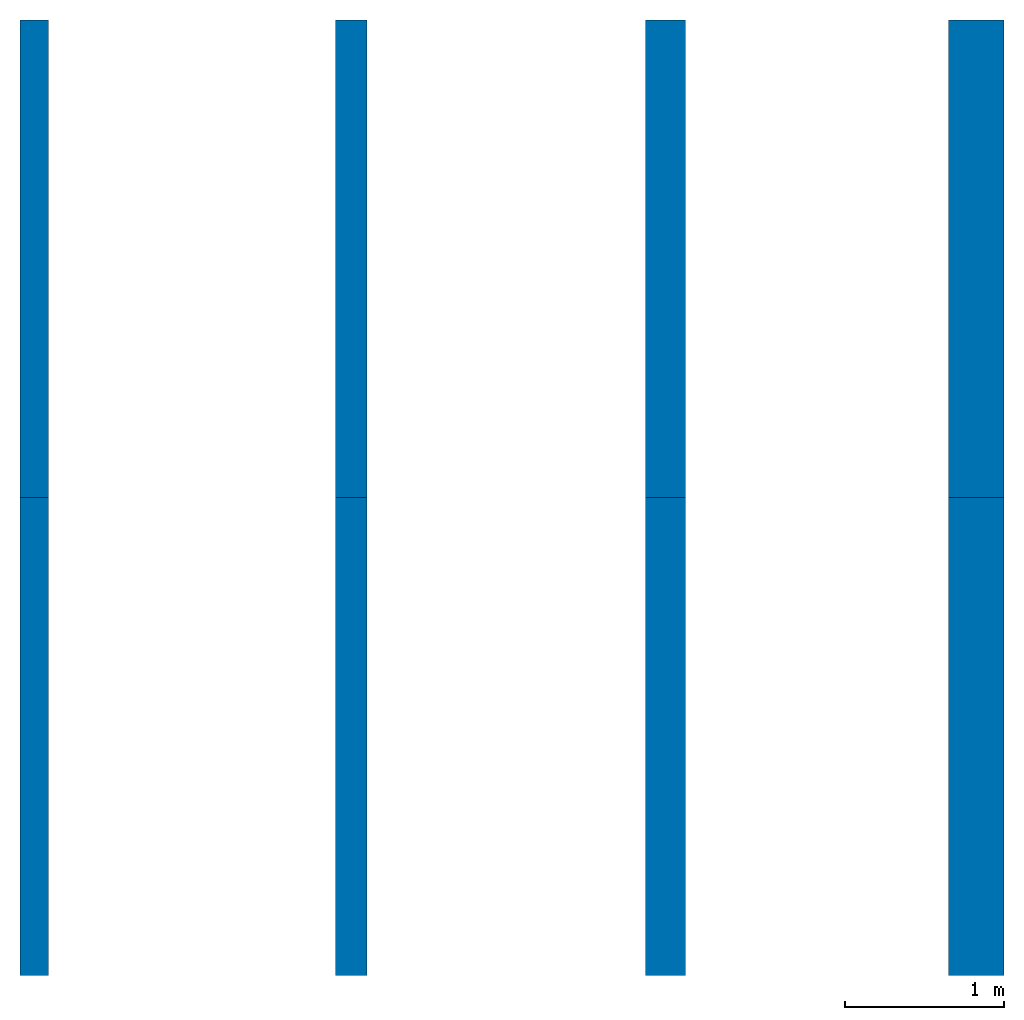
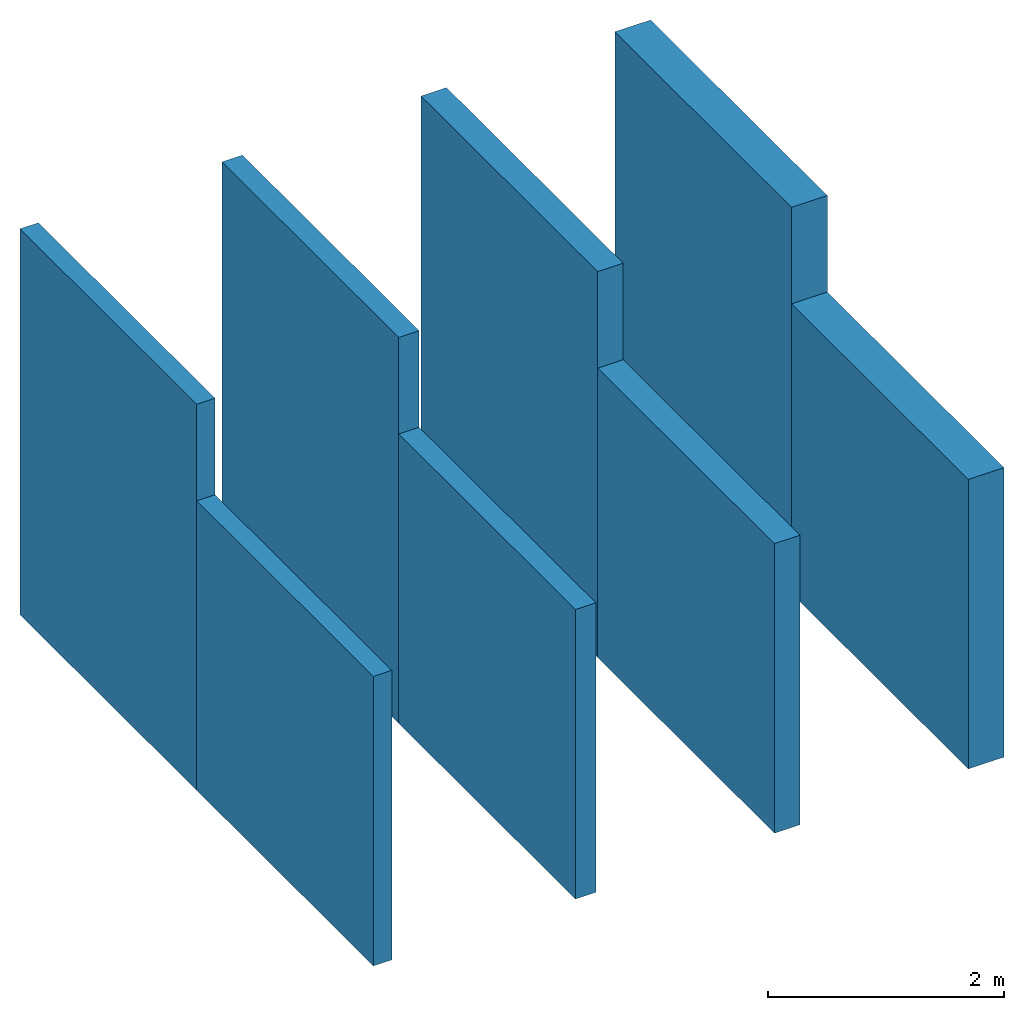
# One storey: 8 walls.
"""IFC4 building model written with IfcOpenShell, lengths in metres."""

import ifcopenshell
import ifcopenshell.guid

model = None  # the IFC model being written
_history = None  # IfcOwnerHistory: only IFC2X3 demands one
_inside = {}  # id of a spatial element -> (the spatial element, [elements in it])
_under = {}  # id of a project, library or spatial element -> (it, [spatial elements below it])
_declared = {}  # id of a project -> (the project, [libraries it declares])
_typed = {}  # id of a type object -> (the type object, [elements of that type])
_made_of = {}  # id of a material, layer set ... -> (it, [elements and type objects made of it])


def new_model(schema):
    """Start an empty IFC model of exactly this schema.

    Asked for "IFC4X3", IfcOpenShell would pick the latest addendum, in which some entities
    have other attributes; the version numbers below select the first issue.
    IFC2X3 requires an IfcOwnerHistory on every rooted entity: one is made here for all.
    """
    global model, _history
    if schema == "IFC4X3":
        model = ifcopenshell.file(schema_version=(4, 3, 0, 0))
    else:
        model = ifcopenshell.file(schema=schema)
    _inside.clear()
    _under.clear()
    _declared.clear()
    _typed.clear()
    _made_of.clear()
    _history = None
    if model.schema == "IFC2X3":
        org = make("IfcOrganization", Name="unknown")
        user = make(
            "IfcPersonAndOrganization",
            ThePerson=make("IfcPerson", FamilyName="unknown"),
            TheOrganization=org,
        )
        app = make(
            "IfcApplication",
            ApplicationDeveloper=org,
            Version="unknown",
            ApplicationFullName="unknown",
            ApplicationIdentifier="unknown",
        )
        _history = make(
            "IfcOwnerHistory",
            OwningUser=user,
            OwningApplication=app,
            ChangeAction="ADDED",
            CreationDate=0,
        )
    return model


def make(cls, **values):
    """One entity of the class cls with the attributes given. An attribute that is None is left unset."""
    return model.create_entity(
        cls, **{name: value for name, value in values.items() if value is not None}
    )


def entity(cls, *values):
    """Any entity or typed value of the class cls, its attributes in the order of the schema. None: left unset."""
    e = model.create_entity(cls)
    for i, value in enumerate(values):
        if value is not None:
            e[i] = value
    return e


def rooted(cls, **values):
    """An entity with a GlobalId (a new one), such as an element, a storey or a relation."""
    return make(cls, GlobalId=ifcopenshell.guid.new(), OwnerHistory=_history, **values)


def si_unit(unit_type, name, prefix=None):
    """IfcSIUnit, for example si_unit("LENGTHUNIT", "METRE", prefix="MILLI")."""
    return make("IfcSIUnit", UnitType=unit_type, Prefix=prefix, Name=name)


def converted_unit(unit_type, name, factor, base, dimensions=None, offset=None):
    """IfcConversionBasedUnit, such as the inch: factor (a typed value) times the base unit."""
    return make(
        "IfcConversionBasedUnit"
        if offset is None
        else "IfcConversionBasedUnitWithOffset",
        ConversionOffset=offset,
        Dimensions=None
        if dimensions is None
        else entity("IfcDimensionalExponents", *dimensions),
        UnitType=unit_type,
        Name=name,
        ConversionFactor=make(
            "IfcMeasureWithUnit", ValueComponent=factor, UnitComponent=base
        ),
    )


def assignment(units):
    """IfcUnitAssignment: the units of a project."""
    return None if units is None else make("IfcUnitAssignment", Units=units)


def point(xyz):
    """IfcCartesianPoint."""
    return None if xyz is None else make("IfcCartesianPoint", Coordinates=xyz)


def direction(xyz):
    """IfcDirection."""
    return None if xyz is None else make("IfcDirection", DirectionRatios=xyz)


def frame(location, z_axis=None, x_axis=None):
    """IfcAxis2Placement3D, a coordinate frame: its origin and axes. An axis left out is left unset."""
    return make(
        "IfcAxis2Placement3D",
        Location=point(location),
        Axis=direction(z_axis),
        RefDirection=direction(x_axis),
    )


def frame_2d(location, x_axis=None):
    """IfcAxis2Placement2D, a coordinate frame in the plane: its origin and x axis."""
    return make(
        "IfcAxis2Placement2D", Location=point(location), RefDirection=direction(x_axis)
    )


def origin_with_axes():
    """The frame at (0, 0, 0) with the z axis (0, 0, 1) and the x axis (1, 0, 0) written out."""
    return frame((0.0, 0.0, 0.0), z_axis=(0.0, 0.0, 1.0), x_axis=(1.0, 0.0, 0.0))


def origin_2d_with_axis():
    """The frame at (0, 0) in the plane with the x axis (1, 0) written out."""
    return frame_2d((0.0, 0.0), x_axis=(1.0, 0.0))


def place(relative_to, where):
    """IfcLocalPlacement: puts the frame where relative to a parent placement (None: the world)."""
    return make(
        "IfcLocalPlacement", PlacementRelTo=relative_to, RelativePlacement=where
    )


def context(
    kind, dimensions, precision=None, world=None, true_north=None, identifier=None
):
    """IfcGeometricRepresentationContext, for example the 3D "Model" context."""
    return make(
        "IfcGeometricRepresentationContext",
        ContextIdentifier=identifier,
        ContextType=kind,
        CoordinateSpaceDimension=dimensions,
        Precision=precision,
        WorldCoordinateSystem=world,
        TrueNorth=true_north,
    )


def subcontext(parent, identifier, kind, view, scale=None):
    """IfcGeometricRepresentationSubContext, for example "Body" below "Model"."""
    return make(
        "IfcGeometricRepresentationSubContext",
        ContextIdentifier=identifier,
        ContextType=kind,
        ParentContext=parent,
        TargetScale=scale,
        TargetView=view,
    )


def project(units=None, contexts=None):
    """IfcProject with its units and contexts."""
    return rooted(
        "IfcProject",
        Name="project",
        RepresentationContexts=contexts,
        UnitsInContext=assignment(units),
    )


def spatial(cls, under=None, at=None, **own):
    """A site, building, storey or space (cls), placed at a placement, below another one or the project."""
    s = rooted(cls, ObjectPlacement=at, **own)
    if under is not None:
        _under.setdefault(under.id(), (under, []))[1].append(s)
    return s


def point_list(points):
    """IfcCartesianPointList2D or 3D."""
    cls = (
        "IfcCartesianPointList2D" if len(points[0]) == 2 else "IfcCartesianPointList3D"
    )
    return make(cls, CoordList=points)


def line(*indices):
    """IfcLineIndex: a straight run through numbered points of an indexed curve."""
    return model.create_entity("IfcLineIndex", indices)


def indexed_curve(points, segments=None, self_intersect=None):
    """IfcIndexedPolyCurve: lines and arcs through numbered points (the first is 1)."""
    return make(
        "IfcIndexedPolyCurve",
        Points=point_list(points),
        Segments=segments,
        SelfIntersect=self_intersect,
    )


def outline(outer, holes=None, kind="AREA"):
    """IfcArbitraryClosedProfileDef: a profile drawn as a closed curve; with holes, ...WithVoids."""
    if holes is None:
        return make("IfcArbitraryClosedProfileDef", ProfileType=kind, OuterCurve=outer)
    return make(
        "IfcArbitraryProfileDefWithVoids",
        ProfileType=kind,
        OuterCurve=outer,
        InnerCurves=holes,
    )


def extrude(swept, where, along, depth):
    """IfcExtrudedAreaSolid: the profile swept, set in the frame where, extruded along a direction by depth."""
    return make(
        "IfcExtrudedAreaSolid",
        SweptArea=swept,
        Position=where,
        ExtrudedDirection=direction(along),
        Depth=depth,
    )


def shape(context_of_items, identifier, shape_type, items):
    """IfcShapeRepresentation: the items that make up one representation, for example the "Body"."""
    return make(
        "IfcShapeRepresentation",
        ContextOfItems=context_of_items,
        RepresentationIdentifier=identifier,
        RepresentationType=shape_type,
        Items=items,
    )


def material(Name=None, Category=None):
    """IfcMaterial."""
    return make("IfcMaterial", Name=Name, Category=Category)


def layer(
    of_material, thickness, ventilated=None, Name=None, Category=None, Priority=None
):
    """IfcMaterialLayer: one layer of a wall or slab, of a material (None: an air gap)."""
    return make(
        "IfcMaterialLayer",
        Material=of_material,
        LayerThickness=thickness,
        IsVentilated=ventilated,
        Name=Name,
        Category=Category,
        Priority=Priority,
    )


def layer_set(layers, Name=None):
    """IfcMaterialLayerSet."""
    return make("IfcMaterialLayerSet", MaterialLayers=layers, LayerSetName=Name)


def layer_usage(for_layer_set, set_direction, sense, offset, extent=None):
    """IfcMaterialLayerSetUsage: how a layer set lies in its element."""
    return make(
        "IfcMaterialLayerSetUsage",
        ForLayerSet=for_layer_set,
        LayerSetDirection=set_direction,
        DirectionSense=sense,
        OffsetFromReferenceLine=offset,
        ReferenceExtent=extent,
    )


def made_of(thing, what):
    """Note that an element or type object is made of a material, layer set ...; save() writes the relation."""
    if what is not None:
        _made_of.setdefault(what.id(), (what, []))[1].append(thing)
    return thing


def type_object(cls, material=None, **own):
    """A type object (cls), such as IfcWallType, which elements share."""
    return made_of(rooted(cls, **own), material)


def element(
    cls,
    number,
    at=None,
    inside=None,
    cuts=None,
    type_object=None,
    material=None,
    context=None,
    identifier="Body",
    shape_type=None,
    held_by="IfcProductDefinitionShape",
    body=None,
    shapes=None,
    **own,
):
    """One element of the class cls, such as IfcWall. Its Tag is "e" and its number.

    at: its placement. inside: the storey or other place that contains it. cuts: it is an
    opening in that element (IfcRelVoidsElement). A single representation is given by context,
    identifier, shape_type and body (its items); several are given by shapes. held_by: the class
    of the entity that holds the representations. save() writes the other relations.
    """
    e = rooted(cls, Tag="e%d" % number, ObjectPlacement=at, **own)
    if body is not None:
        shapes = [shape(context, identifier, shape_type, body)]
    if shapes is not None:
        e.Representation = make(held_by, Representations=shapes)
    if inside is not None:
        _inside.setdefault(inside.id(), (inside, []))[1].append(e)
    if cuts is not None:
        rooted(
            "IfcRelVoidsElement", RelatingBuildingElement=cuts, RelatedOpeningElement=e
        )
    if type_object is not None:
        _typed.setdefault(type_object.id(), (type_object, []))[1].append(e)
    return made_of(e, material)


def aggregate(whole, parts):
    """IfcRelAggregates: a whole, such as a stair, and the parts it consists of."""
    return rooted("IfcRelAggregates", RelatingObject=whole, RelatedObjects=parts)


def save(model, path):
    """Write the relations noted so far, then the file.

    IfcRelAggregates (storeys below a building ...), IfcRelContainedInSpatialStructure (elements
    in a storey), IfcRelDefinesByType, IfcRelAssociatesMaterial and IfcRelDeclares: one each for
    every whole, place, type object, material and project.
    """
    for whole, parts in _under.values():
        aggregate(whole, parts)
    for where, things in _inside.values():
        rooted(
            "IfcRelContainedInSpatialStructure",
            RelatedElements=things,
            RelatingStructure=where,
        )
    for kind, things in _typed.values():
        rooted("IfcRelDefinesByType", RelatedObjects=things, RelatingType=kind)
    for what, things in _made_of.values():
        rooted("IfcRelAssociatesMaterial", RelatedObjects=things, RelatingMaterial=what)
    for by, libraries in _declared.values():
        rooted("IfcRelDeclares", RelatingContext=by, RelatedDefinitions=libraries)
    model.write(path)


model = new_model("IFC4")

# Units and contexts
model_context = context("Model", 3, precision=1e-05, world=origin_with_axes())
plan_context = context("Plan", 2, precision=1e-05, world=origin_2d_with_axis())
body_context = subcontext(model_context, "Body", "Model", "MODEL_VIEW")
ifc_project = project(units=[si_unit("AREAUNIT", "SQUARE_METRE"), si_unit("VOLUMEUNIT", "CUBIC_METRE"), si_unit("LENGTHUNIT", "METRE"), converted_unit("PLANEANGLEUNIT", "degree", entity("IfcReal", 0.0174532925199433), si_unit("PLANEANGLEUNIT", "RADIAN"), dimensions=[0, 0, 0, 0, 0, 0, 0])], contexts=[model_context, plan_context])

# Site, building, storey
site_placement = place(None, origin_with_axes())
site = spatial("IfcSite", under=ifc_project, at=site_placement)
building_placement = place(site_placement, origin_with_axes())
building = spatial("IfcBuilding", under=site, at=building_placement, Name="Building")
storey_placement = place(building_placement, origin_with_axes())
storey = spatial("IfcBuildingStorey", under=building, at=storey_placement, Name="Storey")

# Walls
ifc_material = material(Name="Stahlbeton", Category="Beton")
ifc_layer_1 = layer(ifc_material, 0.200000002980232)
ifc_layer_set_1 = layer_set([ifc_layer_1])
ifc_layer_usage_1 = layer_usage(ifc_layer_set_1, "AXIS2", "POSITIVE", 0.0)
wall_type_1 = type_object("IfcWallType", Name="STB 200", PredefinedType="SOLIDWALL", material=ifc_layer_set_1)
wall_1_placement = place(storey_placement, frame((2.1800000667572, 0.0, 0.0), z_axis=(0.0, 0.0, 1.0), x_axis=(1.94707183709394e-07, 0.999999999999981, 0.0)))
element("IfcWall", 1, at=wall_1_placement, inside=storey, type_object=wall_type_1, material=ifc_layer_usage_1, Name="Wall", context=body_context, shape_type="SweptSolid", body=[
    extrude(outline(indexed_curve([(0.0, 0.0), (0.0, 0.200000002980232), (3.00000000000001, 0.200000002980232), (3.00000000000001, 0.0)], segments=[line(1, 2, 3, 4, 1)])), origin_with_axes(), (0.0, 0.0, 1.0), 3.0),
])
ifc_layer_usage_2 = layer_usage(ifc_layer_set_1, "AXIS2", "POSITIVE", 0.0)
wall_2_placement = place(storey_placement, frame((2.1800000667572, 3.0, 0.0), z_axis=(0.0, 0.0, 1.0), x_axis=(3.13916473260163e-07, 0.999999999999951, 0.0)))
element("IfcWall", 2, at=wall_2_placement, inside=storey, type_object=wall_type_1, material=ifc_layer_usage_2, Name="Wall", context=body_context, shape_type="SweptSolid", body=[
    extrude(outline(indexed_curve([(0.0, 0.0), (0.0, 0.200000002980232), (3.00000000000001, 0.200000002980232), (3.00000000000001, 0.0)], segments=[line(1, 2, 3, 4, 1)])), origin_with_axes(), (0.0, 0.0, 1.0), 4.0),
])
ifc_layer_2 = layer(ifc_material, 0.25, ventilated=False)
ifc_layer_set_2 = layer_set([ifc_layer_2])
ifc_layer_usage_3 = layer_usage(ifc_layer_set_2, "AXIS2", "POSITIVE", 0.0)
wall_type_2 = type_object("IfcWallType", Name="STB 250", PredefinedType="SOLIDWALL", material=ifc_layer_set_2)
wall_3_placement = place(storey_placement, frame((4.18000030517578, 0.0, 0.0), z_axis=(0.0, 0.0, 1.0), x_axis=(1.94707183709394e-07, 0.999999999999981, 0.0)))
element("IfcWall", 3, at=wall_3_placement, inside=storey, type_object=wall_type_2, material=ifc_layer_usage_3, Name="Wall", context=body_context, shape_type="SweptSolid", body=[
    extrude(outline(indexed_curve([(0.0, 0.0), (0.0, 0.25), (3.00000000000001, 0.25), (3.00000000000001, 0.0)], segments=[line(1, 2, 3, 4, 1)])), origin_with_axes(), (0.0, 0.0, 1.0), 3.0),
])
ifc_layer_usage_4 = layer_usage(ifc_layer_set_2, "AXIS2", "POSITIVE", 0.0)
wall_4_placement = place(storey_placement, frame((4.18000030517578, 3.0, 0.0), z_axis=(0.0, 0.0, 1.0), x_axis=(3.13916473260163e-07, 0.999999999999951, 0.0)))
element("IfcWall", 4, at=wall_4_placement, inside=storey, type_object=wall_type_2, material=ifc_layer_usage_4, Name="Wall", context=body_context, shape_type="SweptSolid", body=[
    extrude(outline(indexed_curve([(0.0, 0.0), (0.0, 0.25), (3.00000000000001, 0.25), (3.00000000000001, 0.0)], segments=[line(1, 2, 3, 4, 1)])), origin_with_axes(), (0.0, 0.0, 1.0), 4.0),
])
ifc_layer_3 = layer(ifc_material, 0.349999994039536, ventilated=False)
ifc_layer_set_3 = layer_set([ifc_layer_3])
ifc_layer_usage_5 = layer_usage(ifc_layer_set_3, "AXIS2", "POSITIVE", 0.0)
wall_type_3 = type_object("IfcWallType", Name="STB 350", PredefinedType="SOLIDWALL", material=ifc_layer_set_3)
wall_5_placement = place(storey_placement, frame((6.18000030517578, 0.0, 0.0), z_axis=(0.0, 0.0, 1.0), x_axis=(1.94707183709394e-07, 0.999999999999981, 0.0)))
element("IfcWall", 5, at=wall_5_placement, inside=storey, type_object=wall_type_3, material=ifc_layer_usage_5, Name="Wall", context=body_context, shape_type="SweptSolid", body=[
    extrude(outline(indexed_curve([(0.0, 0.0), (0.0, 0.349999994039536), (3.00000000000001, 0.349999994039536), (3.00000000000001, 0.0)], segments=[line(1, 2, 3, 4, 1)])), origin_with_axes(), (0.0, 0.0, 1.0), 3.0),
])
ifc_layer_usage_6 = layer_usage(ifc_layer_set_3, "AXIS2", "POSITIVE", 0.0)
wall_6_placement = place(storey_placement, frame((6.18000030517578, 3.0, 0.0), z_axis=(0.0, 0.0, 1.0), x_axis=(3.13916473260163e-07, 0.999999999999951, 0.0)))
element("IfcWall", 6, at=wall_6_placement, inside=storey, type_object=wall_type_3, material=ifc_layer_usage_6, Name="Wall", context=body_context, shape_type="SweptSolid", body=[
    extrude(outline(indexed_curve([(0.0, 0.0), (0.0, 0.349999994039536), (3.00000000000001, 0.349999994039536), (3.00000000000001, 0.0)], segments=[line(1, 2, 3, 4, 1)])), origin_with_axes(), (0.0, 0.0, 1.0), 4.0),
])
ifc_layer_4 = layer(ifc_material, 0.180000007152557, ventilated=False)
ifc_layer_set_4 = layer_set([ifc_layer_4])
ifc_layer_usage_7 = layer_usage(ifc_layer_set_4, "AXIS2", "POSITIVE", 0.0)
wall_type_4 = type_object("IfcWallType", Name="STB 180", PredefinedType="SOLIDWALL", material=ifc_layer_set_4)
wall_7_placement = place(storey_placement, frame((0.180000007152557, 0.0, 0.0), z_axis=(0.0, 0.0, 1.0), x_axis=(1.94707183709394e-07, 0.999999999999981, 0.0)))
element("IfcWall", 7, at=wall_7_placement, inside=storey, type_object=wall_type_4, material=ifc_layer_usage_7, Name="Wall", context=body_context, shape_type="SweptSolid", body=[
    extrude(outline(indexed_curve([(0.0, 0.0), (0.0, 0.180000007152557), (3.00000000000001, 0.180000007152557), (3.00000000000001, 0.0)], segments=[line(1, 2, 3, 4, 1)])), origin_with_axes(), (0.0, 0.0, 1.0), 3.0),
])
ifc_layer_usage_8 = layer_usage(ifc_layer_set_4, "AXIS2", "POSITIVE", 0.0)
wall_8_placement = place(storey_placement, frame((0.180000007152557, 3.0, 0.0), z_axis=(0.0, 0.0, 1.0), x_axis=(1.94707183709394e-07, 0.999999999999981, 0.0)))
element("IfcWall", 8, at=wall_8_placement, inside=storey, type_object=wall_type_4, material=ifc_layer_usage_8, Name="Wall", context=body_context, shape_type="SweptSolid", body=[
    extrude(outline(indexed_curve([(0.0, 0.0), (0.0, 0.180000007152557), (3.00000000000001, 0.180000007152557), (3.00000000000001, 0.0)], segments=[line(1, 2, 3, 4, 1)])), origin_with_axes(), (0.0, 0.0, 1.0), 4.0),
])

save(model, "model.ifc")
